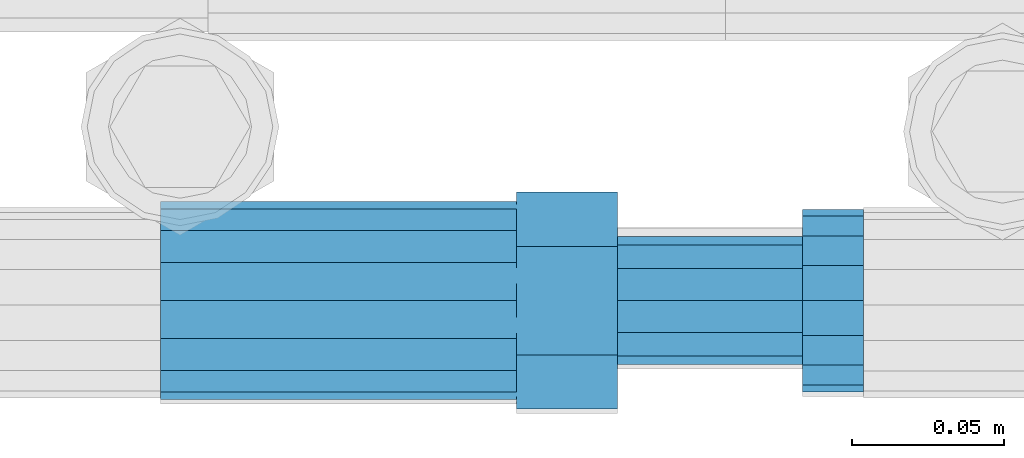
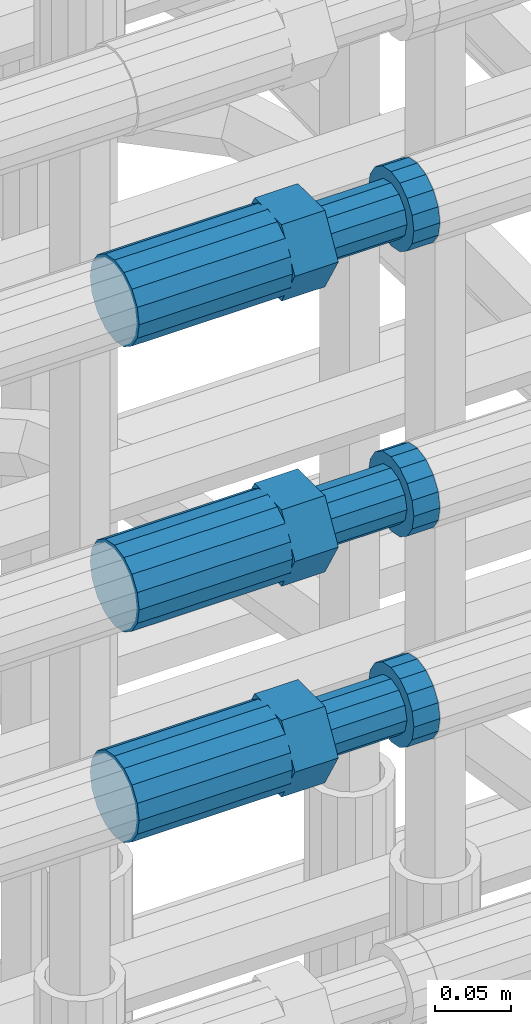
# One storey, part 61 of 119: 3 beams.
"""IFC2X3 building model written with IfcOpenShell, lengths in millimetres."""

import ifcopenshell
import ifcopenshell.guid

model = None  # the IFC model being written
_history = None  # IfcOwnerHistory: only IFC2X3 demands one
_inside = {}  # id of a spatial element -> (the spatial element, [elements in it])
_under = {}  # id of a project, library or spatial element -> (it, [spatial elements below it])
_declared = {}  # id of a project -> (the project, [libraries it declares])
_typed = {}  # id of a type object -> (the type object, [elements of that type])
_made_of = {}  # id of a material, layer set ... -> (it, [elements and type objects made of it])


def new_model(schema):
    """Start an empty IFC model of exactly this schema.

    Asked for "IFC4X3", IfcOpenShell would pick the latest addendum, in which some entities
    have other attributes; the version numbers below select the first issue.
    IFC2X3 requires an IfcOwnerHistory on every rooted entity: one is made here for all.
    """
    global model, _history
    if schema == "IFC4X3":
        model = ifcopenshell.file(schema_version=(4, 3, 0, 0))
    else:
        model = ifcopenshell.file(schema=schema)
    _inside.clear()
    _under.clear()
    _declared.clear()
    _typed.clear()
    _made_of.clear()
    _history = None
    if model.schema == "IFC2X3":
        org = make("IfcOrganization", Name="unknown")
        user = make(
            "IfcPersonAndOrganization",
            ThePerson=make("IfcPerson", FamilyName="unknown"),
            TheOrganization=org,
        )
        app = make(
            "IfcApplication",
            ApplicationDeveloper=org,
            Version="unknown",
            ApplicationFullName="unknown",
            ApplicationIdentifier="unknown",
        )
        _history = make(
            "IfcOwnerHistory",
            OwningUser=user,
            OwningApplication=app,
            ChangeAction="ADDED",
            CreationDate=0,
        )
    return model


def make(cls, **values):
    """One entity of the class cls with the attributes given. An attribute that is None is left unset."""
    return model.create_entity(
        cls, **{name: value for name, value in values.items() if value is not None}
    )


def rooted(cls, **values):
    """An entity with a GlobalId (a new one), such as an element, a storey or a relation."""
    return make(cls, GlobalId=ifcopenshell.guid.new(), OwnerHistory=_history, **values)


def si_unit(unit_type, name, prefix=None):
    """IfcSIUnit, for example si_unit("LENGTHUNIT", "METRE", prefix="MILLI")."""
    return make("IfcSIUnit", UnitType=unit_type, Prefix=prefix, Name=name)


def assignment(units):
    """IfcUnitAssignment: the units of a project."""
    return None if units is None else make("IfcUnitAssignment", Units=units)


def point(xyz):
    """IfcCartesianPoint."""
    return None if xyz is None else make("IfcCartesianPoint", Coordinates=xyz)


def direction(xyz):
    """IfcDirection."""
    return None if xyz is None else make("IfcDirection", DirectionRatios=xyz)


def frame(location, z_axis=None, x_axis=None):
    """IfcAxis2Placement3D, a coordinate frame: its origin and axes. An axis left out is left unset."""
    return make(
        "IfcAxis2Placement3D",
        Location=point(location),
        Axis=direction(z_axis),
        RefDirection=direction(x_axis),
    )


def origin_with_axes():
    """The frame at (0, 0, 0) with the z axis (0, 0, 1) and the x axis (1, 0, 0) written out."""
    return frame((0.0, 0.0, 0.0), z_axis=(0.0, 0.0, 1.0), x_axis=(1.0, 0.0, 0.0))


def place(relative_to, where):
    """IfcLocalPlacement: puts the frame where relative to a parent placement (None: the world)."""
    return make(
        "IfcLocalPlacement", PlacementRelTo=relative_to, RelativePlacement=where
    )


def context(
    kind, dimensions, precision=None, world=None, true_north=None, identifier=None
):
    """IfcGeometricRepresentationContext, for example the 3D "Model" context."""
    return make(
        "IfcGeometricRepresentationContext",
        ContextIdentifier=identifier,
        ContextType=kind,
        CoordinateSpaceDimension=dimensions,
        Precision=precision,
        WorldCoordinateSystem=world,
        TrueNorth=true_north,
    )


def subcontext(parent, identifier, kind, view, scale=None):
    """IfcGeometricRepresentationSubContext, for example "Body" below "Model"."""
    return make(
        "IfcGeometricRepresentationSubContext",
        ContextIdentifier=identifier,
        ContextType=kind,
        ParentContext=parent,
        TargetScale=scale,
        TargetView=view,
    )


def project(units=None, contexts=None):
    """IfcProject with its units and contexts."""
    return rooted(
        "IfcProject",
        Name="project",
        RepresentationContexts=contexts,
        UnitsInContext=assignment(units),
    )


def spatial(cls, under=None, at=None, **own):
    """A site, building, storey or space (cls), placed at a placement, below another one or the project."""
    s = rooted(cls, ObjectPlacement=at, **own)
    if under is not None:
        _under.setdefault(under.id(), (under, []))[1].append(s)
    return s


def faces_of(points, faces, orient=None, outer=None):
    """IfcFace entities. A face is a list of loops; a loop is a list of indices into points, from 0.

    orient and outer hold one flag for each loop. By default every Orientation is true, the
    first loop of a face is its IfcFaceOuterBound and the others are IfcFaceBound.
    """
    made = []
    for i, loops in enumerate(faces):
        bounds = []
        for j, loop in enumerate(loops):
            is_outer = j == 0 if outer is None else outer[i][j]
            bounds.append(
                make(
                    "IfcFaceOuterBound" if is_outer else "IfcFaceBound",
                    Bound=make("IfcPolyLoop", Polygon=[points[k] for k in loop]),
                    Orientation=True if orient is None else orient[i][j],
                )
            )
        made.append(make("IfcFace", Bounds=bounds))
    return made


def faceted_brep(points, faces, orient=None, outer=None, voids=None):
    """IfcFacetedBrep: a solid bounded by flat faces; with voids (closed shells), ...WithVoids."""
    shared = [point(p) for p in points]
    hull = make("IfcClosedShell", CfsFaces=faces_of(shared, faces, orient, outer))
    if voids is None:
        return make("IfcFacetedBrep", Outer=hull)
    return make(
        "IfcFacetedBrepWithVoids",
        Outer=hull,
        Voids=[
            make(cls, CfsFaces=faces_of(shared, fs, o, b)) for cls, fs, o, b in voids
        ],
    )


def shape(context_of_items, identifier, shape_type, items):
    """IfcShapeRepresentation: the items that make up one representation, for example the "Body"."""
    return make(
        "IfcShapeRepresentation",
        ContextOfItems=context_of_items,
        RepresentationIdentifier=identifier,
        RepresentationType=shape_type,
        Items=items,
    )


def material(Name=None, Category=None):
    """IfcMaterial."""
    return make("IfcMaterial", Name=Name, Category=Category)


def made_of(thing, what):
    """Note that an element or type object is made of a material, layer set ...; save() writes the relation."""
    if what is not None:
        _made_of.setdefault(what.id(), (what, []))[1].append(thing)
    return thing


def type_object(cls, material=None, **own):
    """A type object (cls), such as IfcWallType, which elements share."""
    return made_of(rooted(cls, **own), material)


def element(
    cls,
    number,
    at=None,
    inside=None,
    cuts=None,
    type_object=None,
    material=None,
    context=None,
    identifier="Body",
    shape_type=None,
    held_by="IfcProductDefinitionShape",
    body=None,
    shapes=None,
    **own,
):
    """One element of the class cls, such as IfcWall. Its Tag is "e" and its number.

    at: its placement. inside: the storey or other place that contains it. cuts: it is an
    opening in that element (IfcRelVoidsElement). A single representation is given by context,
    identifier, shape_type and body (its items); several are given by shapes. held_by: the class
    of the entity that holds the representations. save() writes the other relations.
    """
    e = rooted(cls, Tag="e%d" % number, ObjectPlacement=at, **own)
    if body is not None:
        shapes = [shape(context, identifier, shape_type, body)]
    if shapes is not None:
        e.Representation = make(held_by, Representations=shapes)
    if inside is not None:
        _inside.setdefault(inside.id(), (inside, []))[1].append(e)
    if cuts is not None:
        rooted(
            "IfcRelVoidsElement", RelatingBuildingElement=cuts, RelatedOpeningElement=e
        )
    if type_object is not None:
        _typed.setdefault(type_object.id(), (type_object, []))[1].append(e)
    return made_of(e, material)


def aggregate(whole, parts):
    """IfcRelAggregates: a whole, such as a stair, and the parts it consists of."""
    return rooted("IfcRelAggregates", RelatingObject=whole, RelatedObjects=parts)


def save(model, path):
    """Write the relations noted so far, then the file.

    IfcRelAggregates (storeys below a building ...), IfcRelContainedInSpatialStructure (elements
    in a storey), IfcRelDefinesByType, IfcRelAssociatesMaterial and IfcRelDeclares: one each for
    every whole, place, type object, material and project.
    """
    for whole, parts in _under.values():
        aggregate(whole, parts)
    for where, things in _inside.values():
        rooted(
            "IfcRelContainedInSpatialStructure",
            RelatedElements=things,
            RelatingStructure=where,
        )
    for kind, things in _typed.values():
        rooted("IfcRelDefinesByType", RelatedObjects=things, RelatingType=kind)
    for what, things in _made_of.values():
        rooted("IfcRelAssociatesMaterial", RelatedObjects=things, RelatingMaterial=what)
    for by, libraries in _declared.values():
        rooted("IfcRelDeclares", RelatingContext=by, RelatedDefinitions=libraries)
    model.write(path)


model = new_model("IFC2X3")

# Units and contexts
model_context = context("Model", 3, precision=1e-05, world=origin_with_axes())
body_context = subcontext(model_context, "Body", "Model", "MODEL_VIEW")
ifc_project = project(units=[si_unit("LENGTHUNIT", "METRE", prefix="MILLI"), si_unit("AREAUNIT", "SQUARE_METRE"), si_unit("VOLUMEUNIT", "CUBIC_METRE"), si_unit("MASSUNIT", "GRAM", prefix="KILO"), si_unit("TIMEUNIT", "SECOND"), si_unit("PLANEANGLEUNIT", "RADIAN"), si_unit("SOLIDANGLEUNIT", "STERADIAN"), si_unit("THERMODYNAMICTEMPERATUREUNIT", "DEGREE_CELSIUS"), si_unit("LUMINOUSINTENSITYUNIT", "LUMEN")], contexts=[model_context])

# Site, building, storey
site_placement = place(None, origin_with_axes())
site = spatial("IfcSite", under=ifc_project, at=site_placement, CompositionType="ELEMENT")
building_placement = place(site_placement, origin_with_axes())
building = spatial("IfcBuilding", under=site, at=building_placement, Name="Undefined", CompositionType="ELEMENT")
storey_placement = place(building_placement, origin_with_axes())
storey = spatial("IfcBuildingStorey", under=building, at=storey_placement, Name="Undefined", CompositionType="ELEMENT", Elevation=0.0)

# Beams
ifc_material = material(Name="STEEL/S275")
beam_type = type_object("IfcBeamType", Name="ROD65", PredefinedType="NOTDEFINED")
beam_1_placement = place(storey_placement, frame((2035848.66023304, 6205098.98994599, 20187.9894151345), z_axis=(0.0, 0.0, 1.0), x_axis=(1.0, 0.0, 0.0)))
element("IfcBeam", 1, at=beam_1_placement, inside=storey, type_object=beam_type, material=ifc_material, Name="AGB40", ObjectType="ROD65", context=body_context, shape_type="Brep", body=[
    faceted_brep([(116.999999999069, 17.8249999252148, 30.8738056446964), (116.999999998137, 22.0056957420893, 23.632628078838), (116.999999999069, 12.4372115600854, 30.0260848066173), (116.999999999069, 8.17543111252598, 30.8738056446964), (117.000000000931, -17.8250000746921, 30.8738056446964), (150.200000001118, -17.8250000723638, 30.8738056446964), (150.199999999255, 17.8249999275431, 30.8738056446964), (117.000000000931, -8.17543109622784, 30.8738056446964), (117.000000001863, -22.0056959956419, 23.6326278985034), (117.000000000931, -12.4372115437873, 30.0260848066173), (117.000000001863, -35.6500000746455, -2.18278728425503e-10), (150.200000002049, -35.6500000723172, -2.18278728425503e-10), (117.000000001863, -30.8443149488885, 8.32369080289209), (117.000000001863, -30.8443149488885, -8.32369080355784), (117.000000002794, -32.4999999918509, 0.0), (117.000000000931, -17.8250000746921, -30.873805645133), (150.200000001118, -17.8250000723638, -30.873805645133), (117.000000001863, -22.0056959961075, -23.6326278982269), (117.000000000931, -8.17543109389953, -30.873805645133), (117.000000000931, -12.4372115437873, -30.0260848066173), (116.999999999069, 17.8249999252148, -30.873805645133), (150.199999999255, 17.8249999275431, -30.873805645133), (116.999999999069, 8.17543111019768, -30.873805645133), (116.999999999069, 12.4372115600854, -30.0260848066173), (116.999999998137, 22.005695742555, -23.6326280785652), (116.999999998137, 35.6499999251682, -2.18278728425503e-10), (150.199999998324, 35.6499999277294, -2.18278728425503e-10), (116.999999998137, 30.8443150522653, -8.32369036550881), (116.999999997206, 32.5000000081491, 0.0), (116.999999998137, 30.8443150522653, 8.32369036483942), (1.86264514923096e-09, -22.9809703885112, 22.9809703885621), (1.86264514923096e-09, -30.0260848065373, 12.4372115518672), (117.000000001863, -30.0260847983882, 12.4372115518672), (117.000000001863, -22.9809703803621, 22.9809703885621), (-1.86264514923096e-09, 22.9809703885112, -22.9809703885621), (-1.86264514923096e-09, 30.0260848065373, -12.4372115518672), (116.999999998137, 30.0260848146863, -12.4372115518672), (116.999999998137, 22.9809703966603, -22.9809703885621), (1.86264514923096e-09, -30.0260848065373, -12.4372115518672), (1.86264514923096e-09, -22.9809703885112, -22.9809703885621), (117.000000001863, -22.9809703803621, -22.9809703885621), (117.000000001863, -30.0260847983882, -12.4372115518672), (9.31322574615479e-10, -12.4372115519363, 30.0260848066173), (0.0, 0.0, 32.5), (-9.31322574615479e-10, 12.4372115519363, 30.0260848066173), (-1.86264514923096e-09, 22.9809703885112, 22.9809703885621), (-1.86264514923096e-09, 30.0260848065373, 12.4372115518672), (-2.79396772384644e-09, 32.5, 0.0), (-9.31322574615479e-10, 12.4372115519363, -30.0260848066173), (0.0, 0.0, -32.5), (9.31322574615479e-10, -12.4372115519363, -30.0260848066173), (2.79396772384644e-09, -32.5, 0.0), (116.999999998137, 22.9809703966603, 22.9809703885621), (116.999999998137, 30.0260848146863, 12.4372115518672), (117.0, 8.14907252788544e-09, -32.5), (117.0, 8.14907252788544e-09, 32.5), (150.200000000186, -10.5000000959262, 18.1865334791873), (150.199999999255, -9.59262251853943e-08, 20.9999999997126), (150.199999998324, 10.4999999040738, 18.1865334791873), (150.199999997392, 18.1865333835594, 10.4999999997126), (150.199999997392, 20.9999999040738, -2.87400325760245e-10), (150.199999997392, 18.1865333835594, -10.5000000002874), (150.199999998324, 10.4999999040738, -18.1865334797621), (150.199999999255, -9.59262251853943e-08, -21.0000000002874), (150.200000000186, -10.5000000959262, -18.1865334797621), (150.200000000186, -18.1865335754119, -10.5000000002874), (150.200000001118, -21.0000000959262, -2.87400325760245e-10), (150.200000000186, -18.1865335754119, 10.4999999997126), (210.979999999516, 10.4999999082647, 18.1865334791873), (210.979999999516, -9.17352735996246e-08, 20.9999999997126), (210.979999997653, 18.1865333877504, 10.4999999997126), (210.979999997653, 20.9999999082647, -2.87400325760245e-10), (210.979999997653, 18.1865333877504, -10.5000000002874), (210.979999999516, 10.4999999082647, -18.1865334797621), (210.979999999516, -9.17352735996246e-08, -21.0000000002874), (210.979999999516, -10.5000000917353, -18.1865334797621), (210.980000000447, -18.1865335712209, -10.5000000002874), (210.980000001378, -21.0000000917353, -2.87400325760245e-10), (210.980000000447, -18.1865335712209, 10.4999999997126), (210.979999999516, -10.5000000917353, 18.1865334791873), (211.001368402503, -27.7269939335529, -11.4911163272045), (211.003082515672, -21.2238095656503, -21.2238154190527), (231.002518340945, -21.2131946226582, -21.2132004554769), (231.000804228708, -27.7163789905608, -11.4805013636287), (211.001368415542, -11.4911086384673, -27.7269970399575), (231.000804241747, -11.4804936954752, -27.7163820763781), (210.996487061493, -0.0106066407170147, -30.0106107396168), (230.995922887698, 8.30227509140968e-06, -29.999995776041), (210.98918159306, 11.4698940692469, -27.7269970332745), (230.988617419265, 11.4805090120062, -27.7163820696951), (210.980564201251, 21.2025913291145, -21.2238154067054), (230.980000027455, 21.2132062721066, -21.2132004431296), (210.971946807578, 27.7057702087332, -11.4911163110701), (230.971382633783, 27.7163851517253, -11.4805013474943), (210.964641331695, 29.9893806746695, -0.0106149565435771), (230.9640771579, 29.9999956176616, 7.03221303410828e-09), (210.959759964608, 27.7057637346443, 11.4698863966551), (230.959195790812, 27.7163786776364, 11.4805013602345), (210.958045851439, 21.2025793667417, 21.2025854885032), (230.957481677644, 21.2131943097338, 21.2132004520827), (210.959759951569, 11.4698784395587, 27.705767109408), (230.959195776843, 11.4804933823179, 27.7163820729838), (210.964641305618, -0.0106235581915826, 29.9893808090674), (230.964077131823, -8.61519947648048e-06, 29.9999957726432), (210.971946774051, -11.4911242681555, 27.7057671027251), (230.971382599324, -11.4805093251634, 27.7163820663009), (210.98056416586, -21.2238215280231, 21.2025854761559), (230.979999991134, -21.2132065852638, 21.2132004397354), (210.989181559533, -27.7270004076418, 11.4698863805206), (230.988617384806, -27.7163854646496, 11.4805013441), (210.996487035416, -30.0106108735781, -0.0106149740058754), (230.995922861621, -29.999995930586, -1.04300852399319e-08)], [[[0, 1, 2, 3]], [[4, 5, 6, 0, 3, 7]], [[8, 4, 7, 9]], [[10, 11, 5, 4, 8, 12]], [[13, 10, 12, 14]], [[15, 16, 11, 10, 13, 17]], [[18, 15, 17, 19]], [[20, 21, 16, 15, 18, 22]], [[20, 22, 23, 24]], [[25, 26, 21, 20, 24, 27]], [[25, 27, 28, 29]], [[30, 31, 32, 33]], [[34, 35, 36, 37]], [[38, 39, 40, 41]], [[31, 30, 42, 43, 44, 45, 46, 47, 35, 34, 48, 49, 50, 39, 38, 51]], [[46, 45, 52, 53]], [[28, 47, 46, 53, 29]], [[27, 36, 35, 47, 28]], [[24, 37, 36, 27]], [[23, 48, 34, 37, 24]], [[22, 54, 49, 48, 23]], [[18, 54, 22]], [[19, 50, 49, 54, 18]], [[17, 40, 39, 50, 19]], [[13, 41, 40, 17]], [[14, 51, 38, 41, 13]], [[12, 32, 31, 51, 14]], [[8, 33, 32, 12]], [[9, 42, 30, 33, 8]], [[7, 55, 43, 42, 9]], [[3, 55, 7]], [[2, 44, 43, 55, 3]], [[1, 52, 45, 44, 2]], [[29, 53, 52, 1]], [[0, 6, 26, 25, 29, 1]], [[5, 11, 16, 21, 26, 6], [56, 57, 58, 59, 60, 61, 62, 63, 64, 65, 66, 67]], [[68, 58, 57, 69]], [[70, 59, 58, 68]], [[71, 60, 59, 70]], [[72, 61, 60, 71]], [[73, 62, 61, 72]], [[74, 63, 62, 73]], [[75, 64, 63, 74]], [[76, 65, 64, 75]], [[77, 66, 65, 76]], [[78, 67, 66, 77]], [[79, 56, 67, 78]], [[69, 57, 56, 79]], [[80, 81, 82, 83]], [[81, 84, 85, 82]], [[84, 86, 87, 85]], [[86, 88, 89, 87]], [[88, 90, 91, 89]], [[90, 92, 93, 91]], [[92, 94, 95, 93]], [[94, 96, 97, 95]], [[96, 98, 99, 97]], [[98, 100, 101, 99]], [[100, 102, 103, 101]], [[102, 104, 105, 103]], [[104, 106, 107, 105]], [[106, 108, 109, 107]], [[108, 110, 111, 109]], [[82, 85, 87, 89, 91, 93, 95, 97, 99, 101, 103, 105, 107, 109, 111, 83]], [[110, 80, 83, 111]], [[108, 106, 104, 102, 100, 98, 96, 94, 92, 90, 88, 86, 84, 81, 80, 110], [78, 77, 76, 75, 74, 73, 72, 71, 70, 68, 69, 79]]]),
])
beam_2_placement = place(storey_placement, frame((2035848.66023304, 6205098.98994599, 20357.9894151345), z_axis=(0.0, 0.0, 1.0), x_axis=(1.0, 0.0, 0.0)))
element("IfcBeam", 2, at=beam_2_placement, inside=storey, type_object=beam_type, material=ifc_material, Name="AGB40", ObjectType="ROD65", context=body_context, shape_type="Brep", body=[
    faceted_brep([(116.999999999069, 17.8249999252148, 30.8738056446964), (116.999999998137, 22.0056957420893, 23.632628078838), (116.999999999069, 12.4372115600854, 30.0260848066173), (116.999999999069, 8.17543111252598, 30.8738056446964), (117.000000000931, -17.8250000746921, 30.8738056446964), (150.200000001118, -17.8250000723638, 30.8738056446964), (150.199999999255, 17.8249999275431, 30.8738056446964), (117.000000000931, -8.17543109622784, 30.8738056446964), (117.000000001863, -22.0056959956419, 23.6326278985034), (117.000000000931, -12.4372115437873, 30.0260848066173), (117.000000001863, -35.6500000746455, -2.18278728425503e-10), (150.200000002049, -35.6500000723172, -2.18278728425503e-10), (117.000000001863, -30.8443149488885, 8.32369080289209), (117.000000001863, -30.8443149488885, -8.32369080355784), (117.000000002794, -32.4999999918509, 0.0), (117.000000000931, -17.8250000746921, -30.873805645133), (150.200000001118, -17.8250000723638, -30.873805645133), (117.000000001863, -22.0056959961075, -23.6326278982269), (117.000000000931, -8.17543109389953, -30.873805645133), (117.000000000931, -12.4372115437873, -30.0260848066173), (116.999999999069, 17.8249999252148, -30.873805645133), (150.199999999255, 17.8249999275431, -30.873805645133), (116.999999999069, 8.17543111019768, -30.873805645133), (116.999999999069, 12.4372115600854, -30.0260848066173), (116.999999998137, 22.005695742555, -23.6326280785652), (116.999999998137, 35.6499999251682, -2.18278728425503e-10), (150.199999998324, 35.6499999277294, -2.18278728425503e-10), (116.999999998137, 30.8443150522653, -8.32369036550881), (116.999999997206, 32.5000000081491, 0.0), (116.999999998137, 30.8443150522653, 8.32369036483942), (1.86264514923096e-09, -22.9809703885112, 22.9809703885621), (1.86264514923096e-09, -30.0260848065373, 12.4372115518672), (117.000000001863, -30.0260847983882, 12.4372115518672), (117.000000001863, -22.9809703803621, 22.9809703885621), (-1.86264514923096e-09, 22.9809703885112, -22.9809703885621), (-1.86264514923096e-09, 30.0260848065373, -12.4372115518672), (116.999999998137, 30.0260848146863, -12.4372115518672), (116.999999998137, 22.9809703966603, -22.9809703885621), (1.86264514923096e-09, -30.0260848065373, -12.4372115518672), (1.86264514923096e-09, -22.9809703885112, -22.9809703885621), (117.000000001863, -22.9809703803621, -22.9809703885621), (117.000000001863, -30.0260847983882, -12.4372115518672), (9.31322574615479e-10, -12.4372115519363, 30.0260848066173), (0.0, 0.0, 32.5), (-9.31322574615479e-10, 12.4372115519363, 30.0260848066173), (-1.86264514923096e-09, 22.9809703885112, 22.9809703885621), (-1.86264514923096e-09, 30.0260848065373, 12.4372115518672), (-2.79396772384644e-09, 32.5, 0.0), (-9.31322574615479e-10, 12.4372115519363, -30.0260848066173), (0.0, 0.0, -32.5), (9.31322574615479e-10, -12.4372115519363, -30.0260848066173), (2.79396772384644e-09, -32.5, 0.0), (116.999999998137, 22.9809703966603, 22.9809703885621), (116.999999998137, 30.0260848146863, 12.4372115518672), (117.0, 8.14907252788544e-09, -32.5), (117.0, 8.14907252788544e-09, 32.5), (150.200000000186, -10.5000000959262, 18.1865334791873), (150.199999999255, -9.59262251853943e-08, 20.9999999997126), (150.199999998324, 10.4999999040738, 18.1865334791873), (150.199999997392, 18.1865333835594, 10.4999999997126), (150.199999997392, 20.9999999040738, -2.87400325760245e-10), (150.199999997392, 18.1865333835594, -10.5000000002874), (150.199999998324, 10.4999999040738, -18.1865334797621), (150.199999999255, -9.59262251853943e-08, -21.0000000002874), (150.200000000186, -10.5000000959262, -18.1865334797621), (150.200000000186, -18.1865335754119, -10.5000000002874), (150.200000001118, -21.0000000959262, -2.87400325760245e-10), (150.200000000186, -18.1865335754119, 10.4999999997126), (210.979999999516, 10.4999999082647, 18.1865334791873), (210.979999999516, -9.17352735996246e-08, 20.9999999997126), (210.979999997653, 18.1865333877504, 10.4999999997126), (210.979999997653, 20.9999999082647, -2.87400325760245e-10), (210.979999997653, 18.1865333877504, -10.5000000002874), (210.979999999516, 10.4999999082647, -18.1865334797621), (210.979999999516, -9.17352735996246e-08, -21.0000000002874), (210.979999999516, -10.5000000917353, -18.1865334797621), (210.980000000447, -18.1865335712209, -10.5000000002874), (210.980000001378, -21.0000000917353, -2.87400325760245e-10), (210.980000000447, -18.1865335712209, 10.4999999997126), (210.979999999516, -10.5000000917353, 18.1865334791873), (211.001368402503, -27.7269939335529, -11.4911163272045), (211.003082515672, -21.2238095656503, -21.2238154190527), (231.002518340945, -21.2131946226582, -21.2132004554769), (231.000804228708, -27.7163789905608, -11.4805013636287), (211.001368415542, -11.4911086384673, -27.7269970399575), (231.000804241747, -11.4804936954752, -27.7163820763781), (210.996487061493, -0.0106066407170147, -30.0106107396168), (230.995922887698, 8.30227509140968e-06, -29.999995776041), (210.98918159306, 11.4698940692469, -27.7269970332745), (230.988617419265, 11.4805090120062, -27.7163820696951), (210.980564201251, 21.2025913291145, -21.2238154067054), (230.980000027455, 21.2132062721066, -21.2132004431296), (210.971946807578, 27.7057702087332, -11.4911163110701), (230.971382633783, 27.7163851517253, -11.4805013474943), (210.964641331695, 29.9893806746695, -0.0106149565435771), (230.9640771579, 29.9999956176616, 7.03221303410828e-09), (210.959759964608, 27.7057637346443, 11.4698863966551), (230.959195790812, 27.7163786776364, 11.4805013602345), (210.958045851439, 21.2025793667417, 21.2025854885032), (230.957481677644, 21.2131943097338, 21.2132004520827), (210.959759951569, 11.4698784395587, 27.705767109408), (230.959195776843, 11.4804933823179, 27.7163820729838), (210.964641305618, -0.0106235581915826, 29.9893808090674), (230.964077131823, -8.61519947648048e-06, 29.9999957726432), (210.971946774051, -11.4911242681555, 27.7057671027251), (230.971382599324, -11.4805093251634, 27.7163820663009), (210.98056416586, -21.2238215280231, 21.2025854761559), (230.979999991134, -21.2132065852638, 21.2132004397354), (210.989181559533, -27.7270004076418, 11.4698863805206), (230.988617384806, -27.7163854646496, 11.4805013441), (210.996487035416, -30.0106108735781, -0.0106149740058754), (230.995922861621, -29.999995930586, -1.04300852399319e-08)], [[[0, 1, 2, 3]], [[4, 5, 6, 0, 3, 7]], [[8, 4, 7, 9]], [[10, 11, 5, 4, 8, 12]], [[13, 10, 12, 14]], [[15, 16, 11, 10, 13, 17]], [[18, 15, 17, 19]], [[20, 21, 16, 15, 18, 22]], [[20, 22, 23, 24]], [[25, 26, 21, 20, 24, 27]], [[25, 27, 28, 29]], [[30, 31, 32, 33]], [[34, 35, 36, 37]], [[38, 39, 40, 41]], [[31, 30, 42, 43, 44, 45, 46, 47, 35, 34, 48, 49, 50, 39, 38, 51]], [[46, 45, 52, 53]], [[28, 47, 46, 53, 29]], [[27, 36, 35, 47, 28]], [[24, 37, 36, 27]], [[23, 48, 34, 37, 24]], [[22, 54, 49, 48, 23]], [[18, 54, 22]], [[19, 50, 49, 54, 18]], [[17, 40, 39, 50, 19]], [[13, 41, 40, 17]], [[14, 51, 38, 41, 13]], [[12, 32, 31, 51, 14]], [[8, 33, 32, 12]], [[9, 42, 30, 33, 8]], [[7, 55, 43, 42, 9]], [[3, 55, 7]], [[2, 44, 43, 55, 3]], [[1, 52, 45, 44, 2]], [[29, 53, 52, 1]], [[0, 6, 26, 25, 29, 1]], [[5, 11, 16, 21, 26, 6], [56, 57, 58, 59, 60, 61, 62, 63, 64, 65, 66, 67]], [[68, 58, 57, 69]], [[70, 59, 58, 68]], [[71, 60, 59, 70]], [[72, 61, 60, 71]], [[73, 62, 61, 72]], [[74, 63, 62, 73]], [[75, 64, 63, 74]], [[76, 65, 64, 75]], [[77, 66, 65, 76]], [[78, 67, 66, 77]], [[79, 56, 67, 78]], [[69, 57, 56, 79]], [[80, 81, 82, 83]], [[81, 84, 85, 82]], [[84, 86, 87, 85]], [[86, 88, 89, 87]], [[88, 90, 91, 89]], [[90, 92, 93, 91]], [[92, 94, 95, 93]], [[94, 96, 97, 95]], [[96, 98, 99, 97]], [[98, 100, 101, 99]], [[100, 102, 103, 101]], [[102, 104, 105, 103]], [[104, 106, 107, 105]], [[106, 108, 109, 107]], [[108, 110, 111, 109]], [[82, 85, 87, 89, 91, 93, 95, 97, 99, 101, 103, 105, 107, 109, 111, 83]], [[110, 80, 83, 111]], [[108, 106, 104, 102, 100, 98, 96, 94, 92, 90, 88, 86, 84, 81, 80, 110], [78, 77, 76, 75, 74, 73, 72, 71, 70, 68, 69, 79]]]),
])
beam_3_placement = place(storey_placement, frame((2035848.66023304, 6205098.98994599, 20587.9894151345), z_axis=(0.0, 0.0, 1.0), x_axis=(1.0, 0.0, 0.0)))
element("IfcBeam", 3, at=beam_3_placement, inside=storey, type_object=beam_type, material=ifc_material, Name="AGB40", ObjectType="ROD65", context=body_context, shape_type="Brep", body=[
    faceted_brep([(116.999999999069, 17.8249999252148, 30.8738056446964), (116.999999998137, 22.0056957420893, 23.632628078838), (116.999999999069, 12.4372115600854, 30.0260848066173), (116.999999999069, 8.17543111252598, 30.8738056446964), (117.000000000931, -17.8250000746921, 30.8738056446964), (150.200000001118, -17.8250000723638, 30.8738056446964), (150.199999999255, 17.8249999275431, 30.8738056446964), (117.000000000931, -8.17543109622784, 30.8738056446964), (117.000000001863, -22.0056959956419, 23.6326278985034), (117.000000000931, -12.4372115437873, 30.0260848066173), (117.000000001863, -35.6500000746455, -2.18278728425503e-10), (150.200000002049, -35.6500000723172, -2.18278728425503e-10), (117.000000001863, -30.8443149488885, 8.32369080289209), (117.000000001863, -30.8443149488885, -8.32369080355784), (117.000000002794, -32.4999999918509, 0.0), (117.000000000931, -17.8250000746921, -30.873805645133), (150.200000001118, -17.8250000723638, -30.873805645133), (117.000000001863, -22.0056959961075, -23.6326278982269), (117.000000000931, -8.17543109389953, -30.873805645133), (117.000000000931, -12.4372115437873, -30.0260848066173), (116.999999999069, 17.8249999252148, -30.873805645133), (150.199999999255, 17.8249999275431, -30.873805645133), (116.999999999069, 8.17543111019768, -30.873805645133), (116.999999999069, 12.4372115600854, -30.0260848066173), (116.999999998137, 22.005695742555, -23.6326280785652), (116.999999998137, 35.6499999251682, -2.18278728425503e-10), (150.199999998324, 35.6499999277294, -2.18278728425503e-10), (116.999999998137, 30.8443150522653, -8.32369036550881), (116.999999997206, 32.5000000081491, 0.0), (116.999999998137, 30.8443150522653, 8.32369036483942), (1.86264514923096e-09, -22.9809703885112, 22.9809703885621), (1.86264514923096e-09, -30.0260848065373, 12.4372115518672), (117.000000001863, -30.0260847983882, 12.4372115518672), (117.000000001863, -22.9809703803621, 22.9809703885621), (-1.86264514923096e-09, 22.9809703885112, -22.9809703885621), (-1.86264514923096e-09, 30.0260848065373, -12.4372115518672), (116.999999998137, 30.0260848146863, -12.4372115518672), (116.999999998137, 22.9809703966603, -22.9809703885621), (1.86264514923096e-09, -30.0260848065373, -12.4372115518672), (1.86264514923096e-09, -22.9809703885112, -22.9809703885621), (117.000000001863, -22.9809703803621, -22.9809703885621), (117.000000001863, -30.0260847983882, -12.4372115518672), (9.31322574615479e-10, -12.4372115519363, 30.0260848066173), (0.0, 0.0, 32.5), (-9.31322574615479e-10, 12.4372115519363, 30.0260848066173), (-1.86264514923096e-09, 22.9809703885112, 22.9809703885621), (-1.86264514923096e-09, 30.0260848065373, 12.4372115518672), (-2.79396772384644e-09, 32.5, 0.0), (-9.31322574615479e-10, 12.4372115519363, -30.0260848066173), (0.0, 0.0, -32.5), (9.31322574615479e-10, -12.4372115519363, -30.0260848066173), (2.79396772384644e-09, -32.5, 0.0), (116.999999998137, 22.9809703966603, 22.9809703885621), (116.999999998137, 30.0260848146863, 12.4372115518672), (117.0, 8.14907252788544e-09, -32.5), (117.0, 8.14907252788544e-09, 32.5), (150.200000000186, -10.5000000959262, 18.1865334791873), (150.199999999255, -9.59262251853943e-08, 20.9999999997126), (150.199999998324, 10.4999999040738, 18.1865334791873), (150.199999997392, 18.1865333835594, 10.4999999997126), (150.199999997392, 20.9999999040738, -2.87400325760245e-10), (150.199999997392, 18.1865333835594, -10.5000000002874), (150.199999998324, 10.4999999040738, -18.1865334797621), (150.199999999255, -9.59262251853943e-08, -21.0000000002874), (150.200000000186, -10.5000000959262, -18.1865334797621), (150.200000000186, -18.1865335754119, -10.5000000002874), (150.200000001118, -21.0000000959262, -2.87400325760245e-10), (150.200000000186, -18.1865335754119, 10.4999999997126), (210.979999999516, 10.4999999082647, 18.1865334791873), (210.979999999516, -9.17352735996246e-08, 20.9999999997126), (210.979999997653, 18.1865333877504, 10.4999999997126), (210.979999997653, 20.9999999082647, -2.87400325760245e-10), (210.979999997653, 18.1865333877504, -10.5000000002874), (210.979999999516, 10.4999999082647, -18.1865334797621), (210.979999999516, -9.17352735996246e-08, -21.0000000002874), (210.979999999516, -10.5000000917353, -18.1865334797621), (210.980000000447, -18.1865335712209, -10.5000000002874), (210.980000001378, -21.0000000917353, -2.87400325760245e-10), (210.980000000447, -18.1865335712209, 10.4999999997126), (210.979999999516, -10.5000000917353, 18.1865334791873), (211.001368402503, -27.7269939335529, -11.4911163272045), (211.003082515672, -21.2238095656503, -21.2238154190527), (231.002518340945, -21.2131946226582, -21.2132004554769), (231.000804228708, -27.7163789905608, -11.4805013636287), (211.001368415542, -11.4911086384673, -27.7269970399575), (231.000804241747, -11.4804936954752, -27.7163820763781), (210.996487061493, -0.0106066407170147, -30.0106107396168), (230.995922887698, 8.30227509140968e-06, -29.999995776041), (210.98918159306, 11.4698940692469, -27.7269970332745), (230.988617419265, 11.4805090120062, -27.7163820696951), (210.980564201251, 21.2025913291145, -21.2238154067054), (230.980000027455, 21.2132062721066, -21.2132004431296), (210.971946807578, 27.7057702087332, -11.4911163110701), (230.971382633783, 27.7163851517253, -11.4805013474943), (210.964641331695, 29.9893806746695, -0.0106149565435771), (230.9640771579, 29.9999956176616, 7.03221303410828e-09), (210.959759964608, 27.7057637346443, 11.4698863966551), (230.959195790812, 27.7163786776364, 11.4805013602345), (210.958045851439, 21.2025793667417, 21.2025854885032), (230.957481677644, 21.2131943097338, 21.2132004520827), (210.959759951569, 11.4698784395587, 27.705767109408), (230.959195776843, 11.4804933823179, 27.7163820729838), (210.964641305618, -0.0106235581915826, 29.9893808090674), (230.964077131823, -8.61519947648048e-06, 29.9999957726432), (210.971946774051, -11.4911242681555, 27.7057671027251), (230.971382599324, -11.4805093251634, 27.7163820663009), (210.98056416586, -21.2238215280231, 21.2025854761559), (230.979999991134, -21.2132065852638, 21.2132004397354), (210.989181559533, -27.7270004076418, 11.4698863805206), (230.988617384806, -27.7163854646496, 11.4805013441), (210.996487035416, -30.0106108735781, -0.0106149740058754), (230.995922861621, -29.999995930586, -1.04300852399319e-08)], [[[0, 1, 2, 3]], [[4, 5, 6, 0, 3, 7]], [[8, 4, 7, 9]], [[10, 11, 5, 4, 8, 12]], [[13, 10, 12, 14]], [[15, 16, 11, 10, 13, 17]], [[18, 15, 17, 19]], [[20, 21, 16, 15, 18, 22]], [[20, 22, 23, 24]], [[25, 26, 21, 20, 24, 27]], [[25, 27, 28, 29]], [[30, 31, 32, 33]], [[34, 35, 36, 37]], [[38, 39, 40, 41]], [[31, 30, 42, 43, 44, 45, 46, 47, 35, 34, 48, 49, 50, 39, 38, 51]], [[46, 45, 52, 53]], [[28, 47, 46, 53, 29]], [[27, 36, 35, 47, 28]], [[24, 37, 36, 27]], [[23, 48, 34, 37, 24]], [[22, 54, 49, 48, 23]], [[18, 54, 22]], [[19, 50, 49, 54, 18]], [[17, 40, 39, 50, 19]], [[13, 41, 40, 17]], [[14, 51, 38, 41, 13]], [[12, 32, 31, 51, 14]], [[8, 33, 32, 12]], [[9, 42, 30, 33, 8]], [[7, 55, 43, 42, 9]], [[3, 55, 7]], [[2, 44, 43, 55, 3]], [[1, 52, 45, 44, 2]], [[29, 53, 52, 1]], [[0, 6, 26, 25, 29, 1]], [[5, 11, 16, 21, 26, 6], [56, 57, 58, 59, 60, 61, 62, 63, 64, 65, 66, 67]], [[68, 58, 57, 69]], [[70, 59, 58, 68]], [[71, 60, 59, 70]], [[72, 61, 60, 71]], [[73, 62, 61, 72]], [[74, 63, 62, 73]], [[75, 64, 63, 74]], [[76, 65, 64, 75]], [[77, 66, 65, 76]], [[78, 67, 66, 77]], [[79, 56, 67, 78]], [[69, 57, 56, 79]], [[80, 81, 82, 83]], [[81, 84, 85, 82]], [[84, 86, 87, 85]], [[86, 88, 89, 87]], [[88, 90, 91, 89]], [[90, 92, 93, 91]], [[92, 94, 95, 93]], [[94, 96, 97, 95]], [[96, 98, 99, 97]], [[98, 100, 101, 99]], [[100, 102, 103, 101]], [[102, 104, 105, 103]], [[104, 106, 107, 105]], [[106, 108, 109, 107]], [[108, 110, 111, 109]], [[82, 85, 87, 89, 91, 93, 95, 97, 99, 101, 103, 105, 107, 109, 111, 83]], [[110, 80, 83, 111]], [[108, 106, 104, 102, 100, 98, 96, 94, 92, 90, 88, 86, 84, 81, 80, 110], [78, 77, 76, 75, 74, 73, 72, 71, 70, 68, 69, 79]]]),
])

save(model, "model.ifc")
